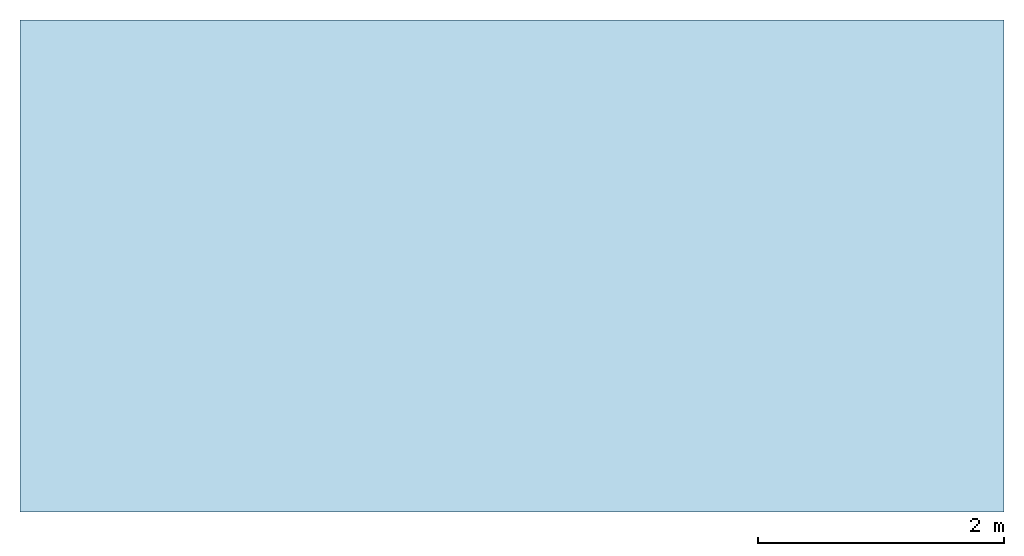
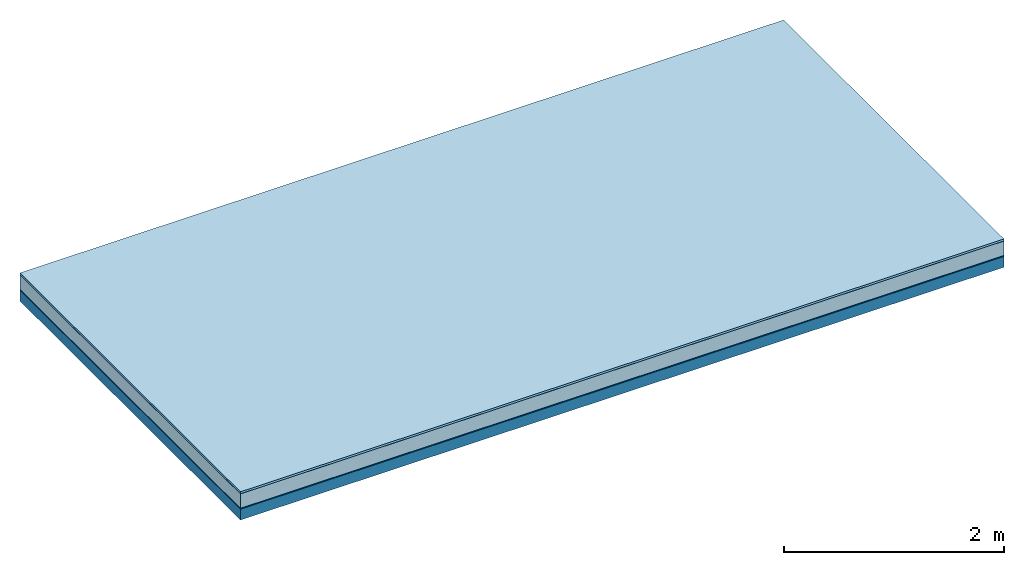
# One storey: 5 plates, 1 member, 1 element without a shape of its own.
"""IFC4 building model written with IfcOpenShell, lengths in metres."""

from ifc_helpers import new_model, si_unit, derived_unit, direction, frame, frame_2d, origin, origin_with_axes, place, context, project, spatial, rectangle, extrude, material, layer, layer_set, type_object, element, aggregate, save


model = new_model("IFC4")

# Units and contexts
plan_context = context("Plan", 3, precision=1e-05, world=origin(), true_north=direction((0.0, 1.0)))
model_context = context("Model", 3, precision=1e-05, world=origin(), true_north=direction((0.0, 1.0)))
ifc_project = project(units=[si_unit("LENGTHUNIT", "METRE"), derived_unit("SOUNDPRESSUREUNIT", [(si_unit("PRESSUREUNIT", "PASCAL", prefix="MICRO"), 0)]), si_unit("ENERGYUNIT", "JOULE", prefix="MEGA"), si_unit("MASSUNIT", "GRAM", prefix="KILO"), derived_unit("THERMALTRANSMITTANCEUNIT", [(si_unit("POWERUNIT", "WATT"), 1), (si_unit("AREAUNIT", "SQUARE_METRE"), -1), (si_unit("THERMODYNAMICTEMPERATUREUNIT", "KELVIN"), -1)]), derived_unit("AREADENSITYUNIT", [(si_unit("MASSUNIT", "GRAM", prefix="KILO"), 1), (si_unit("AREAUNIT", "SQUARE_METRE"), -1)]), derived_unit("USERDEFINED", [(si_unit("ENERGYUNIT", "JOULE", prefix="MEGA"), 1), (si_unit("AREAUNIT", "SQUARE_METRE"), -1)])], contexts=[plan_context, model_context])

# Site, building, storey
site = spatial("IfcSite", under=ifc_project)
building_placement = place(None, origin())
building = spatial("IfcBuilding", under=site, at=building_placement)
storey_placement = place(building_placement, origin())
storey = spatial("IfcBuildingStorey", under=building, at=storey_placement)

# Slab, member, plates
ifc_material_1 = material(Name="with tongue and groove", Category="07.009")
ifc_layer_1 = layer(ifc_material_1, 0.022, Name="Flooring")
ifc_material_2 = material(Category="09.006")
ifc_layer_2 = layer(ifc_material_2, 0.0005, Name="layer")
ifc_material_3 = material(Name="2x 60x80mm")
ifc_layer_3 = layer(ifc_material_3, 0.16, Name="On-material")
ifc_material_4 = material(Name="Wood fiber generic product", Category="10.009")
ifc_layer_4 = layer(ifc_material_4, 0.01, Name="Impact sound insulation")
ifc_material_5 = material(Name="protection", Category="09.007")
ifc_layer_5 = layer(ifc_material_5, 0.0005, Name="Sub-floor")
ifc_material_6 = material(Name="no composite action")
ifc_layer_6 = layer(ifc_material_6, 0.0, Name="Bond")
ifc_layer_7 = layer(None, 0.12, Name="Supporting structure")
ifc_layer_set = layer_set([ifc_layer_1, ifc_layer_2, ifc_layer_3, ifc_layer_4, ifc_layer_5, ifc_layer_6, ifc_layer_7])
slab_type = type_object("IfcSlabType", Name="A2024", PredefinedType="NOTDEFINED", material=ifc_layer_set)
slab_placement = place(None, frame((0.0, 0.0, 0.0), z_axis=(0.0, 0.0, -1.0), x_axis=(1.0, 0.0, 0.0)))
slab = element("IfcSlab", 1, at=slab_placement, inside=storey, type_object=slab_type, material=ifc_layer_set, Name="Slab #1")
ifc_material_7 = material(Name="Solid timber panel")
member_placement = place(slab_placement, origin())
member = element("IfcMember", 2, at=member_placement, material=ifc_material_7, Name="Supporting structure", context=plan_context, shape_type="SweptSolid", body=[
    extrude(rectangle(XDim=1.0, YDim=0.12, at=frame_2d((0.5, 0.06), x_axis=(1.0, 0.0))), frame((0.0, 4.0, 0.193), z_axis=(0.0, -1.0, 0.0), x_axis=(1.0, 0.0, 0.0)), (0.0, 0.0, 1.0), 4.0),
    extrude(rectangle(XDim=1.0, YDim=0.12, at=frame_2d((0.5, 0.06), x_axis=(1.0, 0.0))), frame((1.0, 4.0, 0.193), z_axis=(0.0, -1.0, 0.0), x_axis=(1.0, 0.0, 0.0)), (0.0, 0.0, 1.0), 4.0),
    extrude(rectangle(XDim=1.0, YDim=0.12, at=frame_2d((0.5, 0.06), x_axis=(1.0, 0.0))), frame((2.0, 4.0, 0.193), z_axis=(0.0, -1.0, 0.0), x_axis=(1.0, 0.0, 0.0)), (0.0, 0.0, 1.0), 4.0),
    extrude(rectangle(XDim=1.0, YDim=0.12, at=frame_2d((0.5, 0.06), x_axis=(1.0, 0.0))), frame((3.0, 4.0, 0.193), z_axis=(0.0, -1.0, 0.0), x_axis=(1.0, 0.0, 0.0)), (0.0, 0.0, 1.0), 4.0),
    extrude(rectangle(XDim=1.0, YDim=0.12, at=frame_2d((0.5, 0.06), x_axis=(1.0, 0.0))), frame((4.0, 4.0, 0.193), z_axis=(0.0, -1.0, 0.0), x_axis=(1.0, 0.0, 0.0)), (0.0, 0.0, 1.0), 4.0),
    extrude(rectangle(XDim=1.0, YDim=0.12, at=frame_2d((0.5, 0.06), x_axis=(1.0, 0.0))), frame((5.0, 4.0, 0.193), z_axis=(0.0, -1.0, 0.0), x_axis=(1.0, 0.0, 0.0)), (0.0, 0.0, 1.0), 4.0),
    extrude(rectangle(XDim=1.0, YDim=0.12, at=frame_2d((0.5, 0.06), x_axis=(1.0, 0.0))), frame((6.0, 4.0, 0.193), z_axis=(0.0, -1.0, 0.0), x_axis=(1.0, 0.0, 0.0)), (0.0, 0.0, 1.0), 4.0),
    extrude(rectangle(XDim=1.0, YDim=0.12, at=frame_2d((0.5, 0.06), x_axis=(1.0, 0.0))), frame((7.0, 4.0, 0.193), z_axis=(0.0, -1.0, 0.0), x_axis=(1.0, 0.0, 0.0)), (0.0, 0.0, 1.0), 4.0),
])
plate_1_placement = place(slab_placement, origin())
plate_1 = element("IfcPlate", 3, at=plate_1_placement, material=ifc_material_1, Name="Flooring", context=plan_context, shape_type="SweptSolid", body=[
    extrude(rectangle(XDim=8.0, YDim=4.0, at=frame_2d((4.0, 2.0), x_axis=(1.0, 0.0))), origin_with_axes(), (0.0, 0.0, 1.0), 0.022),
])
plate_2_placement = place(slab_placement, origin())
plate_2 = element("IfcPlate", 4, at=plate_2_placement, material=ifc_material_2, Name="layer", context=plan_context, shape_type="SweptSolid", body=[
    extrude(rectangle(XDim=8.0, YDim=4.0, at=frame_2d((4.0, 2.0), x_axis=(1.0, 0.0))), frame((0.0, 0.0, 0.022), z_axis=(0.0, 0.0, 1.0), x_axis=(1.0, 0.0, 0.0)), (0.0, 0.0, 1.0), 0.0005),
])
plate_3_placement = place(slab_placement, origin())
plate_3 = element("IfcPlate", 5, at=plate_3_placement, material=ifc_material_3, Name="On-material", context=plan_context, shape_type="SweptSolid", body=[
    extrude(rectangle(XDim=8.0, YDim=4.0, at=frame_2d((4.0, 2.0), x_axis=(1.0, 0.0))), frame((0.0, 0.0, 0.0225), z_axis=(0.0, 0.0, 1.0), x_axis=(1.0, 0.0, 0.0)), (0.0, 0.0, 1.0), 0.16),
])
plate_4_placement = place(slab_placement, origin())
plate_4 = element("IfcPlate", 6, at=plate_4_placement, material=ifc_material_4, Name="Impact sound insulation", context=plan_context, shape_type="SweptSolid", body=[
    extrude(rectangle(XDim=8.0, YDim=4.0, at=frame_2d((4.0, 2.0), x_axis=(1.0, 0.0))), frame((0.0, 0.0, 0.1825), z_axis=(0.0, 0.0, 1.0), x_axis=(1.0, 0.0, 0.0)), (0.0, 0.0, 1.0), 0.01),
])
plate_5_placement = place(slab_placement, origin())
plate_5 = element("IfcPlate", 7, at=plate_5_placement, material=ifc_material_5, Name="Sub-floor", context=plan_context, shape_type="SweptSolid", body=[
    extrude(rectangle(XDim=8.0, YDim=4.0, at=frame_2d((4.0, 2.0), x_axis=(1.0, 0.0))), frame((0.0, 0.0, 0.1925), z_axis=(0.0, 0.0, 1.0), x_axis=(1.0, 0.0, 0.0)), (0.0, 0.0, 1.0), 0.0005),
])
aggregate(slab, [plate_1, plate_2, plate_3, plate_4, plate_5, member])

save(model, "model.ifc")
